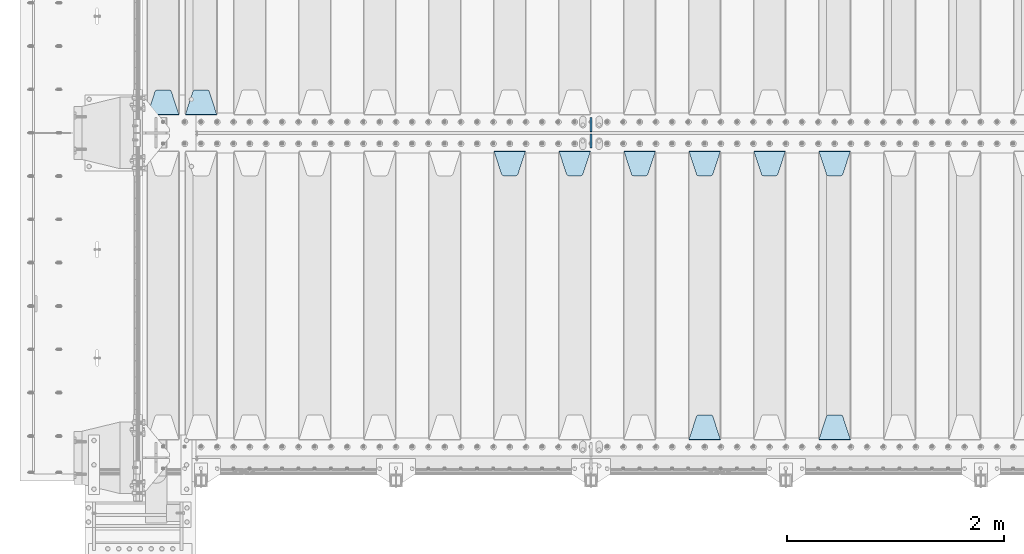
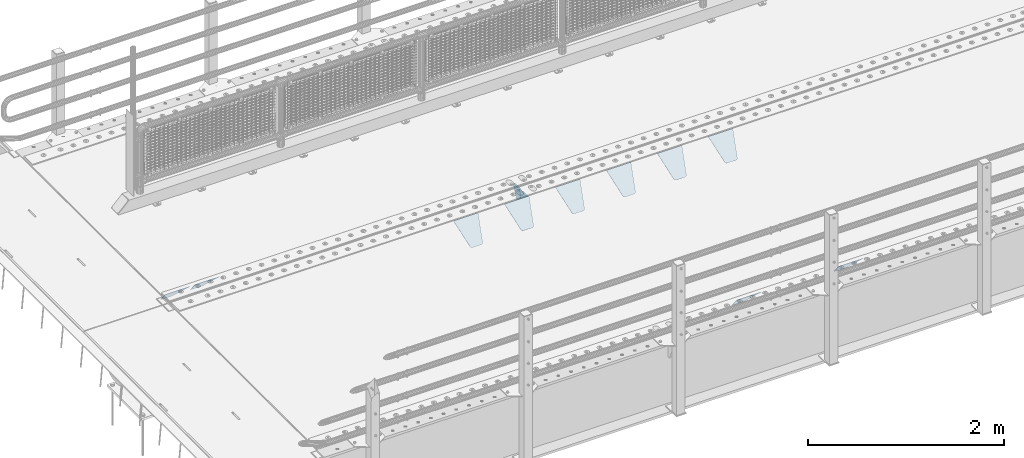
# One storey, part 157 of 193: 12 plates.
"""IFC2X3 building model written with IfcOpenShell, lengths in millimetres."""

from ifc_helpers import new_model, si_unit, frame, origin_with_axes, place, context, subcontext, project, spatial, faceted_brep, material, type_object, element, save


model = new_model("IFC2X3")

# Units and contexts
model_context = context("Model", 3, precision=1e-05, world=origin_with_axes())
body_context = subcontext(model_context, "Body", "Model", "MODEL_VIEW")
ifc_project = project(units=[si_unit("LENGTHUNIT", "METRE", prefix="MILLI"), si_unit("AREAUNIT", "SQUARE_METRE"), si_unit("VOLUMEUNIT", "CUBIC_METRE"), si_unit("MASSUNIT", "GRAM", prefix="KILO"), si_unit("TIMEUNIT", "SECOND"), si_unit("PLANEANGLEUNIT", "RADIAN"), si_unit("SOLIDANGLEUNIT", "STERADIAN"), si_unit("THERMODYNAMICTEMPERATUREUNIT", "DEGREE_CELSIUS"), si_unit("LUMINOUSINTENSITYUNIT", "LUMEN")], contexts=[model_context])

# Site, building, storey
site_placement = place(None, origin_with_axes())
site = spatial("IfcSite", under=ifc_project, at=site_placement, CompositionType="ELEMENT")
building_placement = place(site_placement, origin_with_axes())
building = spatial("IfcBuilding", under=site, at=building_placement, Name="Standard", CompositionType="ELEMENT")
storey_placement = place(building_placement, origin_with_axes())
storey = spatial("IfcBuildingStorey", under=building, at=storey_placement, Name="Undefined", CompositionType="ELEMENT", Elevation=0.0)

# Plates
ifc_material = material(Name="STEEL/S355N")
plate_type_1 = type_object("IfcPlateType", PredefinedType="NOTDEFINED")
plate_1_placement = place(storey_placement, frame((-41755.0, 27168.232233047, -1.76776695296758), z_axis=(0.0, 0.707106781186547, -0.707106781186548), x_axis=(-1.0, 0.0, 0.0)))
element("IfcPlate", 1, at=plate_1_placement, inside=storey, type_object=plate_type_1, material=ifc_material, context=body_context, shape_type="Brep", body=[
    faceted_brep([(0.0, -2.5, 0.0), (69.345504679477, -2.50000000000364, 300.171731424831), (69.345504679477, 2.49999999999636, 300.171731424831), (0.0, 2.5, 0.0), (70.9274061199576, -2.50000000000364, 304.897442415397), (70.9274061199576, 2.49999999999636, 304.897442415397), (73.3818627772307, -2.50000000000364, 309.234538108529), (73.3818627772307, 2.49999999999636, 309.234538108529), (76.6187032999551, -2.50000000000728, 313.023683126103), (76.6187032999551, 2.49999999999636, 313.023683126103), (80.5190132704993, -2.50000000000364, 316.125672595372), (80.5190132704993, 2.49999999999636, 316.125672595368), (84.9395038596849, -2.50000000000364, 318.426546230472), (84.9395038596849, 2.49999999999636, 318.426546230476), (89.7177759439219, -2.50000000000364, 319.841774983273), (89.7177759439219, 2.49999999999636, 319.841774983277), (94.678286292652, -2.50000000000364, 320.319366455074), (94.678286292652, 2.49999999999636, 320.319366455074), (195.321713707348, -2.50000000000364, 320.319366455074), (195.321713707348, 2.49999999999636, 320.319366455074), (200.282224056078, -2.50000000000364, 319.841774983273), (200.282224056078, 2.49999999999636, 319.841774983277), (205.060496140315, -2.50000000000364, 318.426546230472), (205.060496140315, 2.49999999999636, 318.426546230472), (209.480986729501, -2.50000000000364, 316.125672595372), (209.480986729501, 2.49999999999636, 316.125672595368), (213.381296700045, -2.50000000000728, 313.023683126103), (213.381296700045, 2.49999999999272, 313.023683126103), (216.618137222769, -2.50000000000364, 309.234538108525), (216.618137222769, 2.49999999999636, 309.234538108522), (219.072593880042, -2.50000000000364, 304.897442415397), (219.072593880042, 2.49999999999636, 304.897442415397), (220.654495320523, -2.50000000000364, 300.171731424831), (220.654495320523, 2.49999999999636, 300.171731424831), (290.0, -2.50000000000364, 0.0), (290.0, 2.49999999999636, 0.0)], [[[0, 1, 2, 3]], [[1, 4, 5, 2]], [[4, 6, 7, 5]], [[6, 8, 9, 7]], [[8, 10, 11, 9]], [[10, 12, 13, 11]], [[12, 14, 15, 13]], [[14, 16, 17, 15]], [[16, 18, 19, 17]], [[18, 20, 21, 19]], [[20, 22, 23, 21]], [[22, 24, 25, 23]], [[24, 26, 27, 25]], [[26, 28, 29, 27]], [[28, 30, 31, 29]], [[30, 32, 33, 31]], [[32, 34, 35, 33]], [[34, 0, 3, 35]], [[5, 7, 9, 11, 13, 15, 17, 19, 21, 23, 25, 27, 29, 31, 33, 35, 3, 2]], [[34, 32, 30, 28, 26, 24, 22, 20, 18, 16, 14, 12, 10, 8, 6, 4, 1, 0]]]),
])
plate_2_placement = place(storey_placement, frame((-36195.0, 26831.767766956, -1.76776695296758), z_axis=(0.0, -0.707106781186547, -0.707106781186548), x_axis=(1.0, 0.0, 0.0)))
element("IfcPlate", 2, at=plate_2_placement, inside=storey, type_object=plate_type_1, material=ifc_material, context=body_context, shape_type="Brep", body=[
    faceted_brep([(0.0, -2.5, 0.0), (69.345504679477, -2.50000000000364, 300.171731424831), (69.345504679477, 2.49999999999636, 300.171731424831), (0.0, 2.5, 0.0), (70.9274061199576, -2.50000000000364, 304.897442415397), (70.9274061199576, 2.49999999999636, 304.897442415397), (73.3818627772307, -2.50000000000364, 309.234538108529), (73.3818627772307, 2.49999999999636, 309.234538108529), (76.6187032999551, -2.50000000000728, 313.023683126103), (76.6187032999551, 2.49999999999636, 313.023683126103), (80.5190132704993, -2.50000000000364, 316.125672595372), (80.5190132704993, 2.49999999999636, 316.125672595368), (84.9395038596849, -2.50000000000364, 318.426546230472), (84.9395038596849, 2.49999999999636, 318.426546230476), (89.7177759439219, -2.50000000000364, 319.841774983273), (89.7177759439219, 2.49999999999636, 319.841774983277), (94.678286292652, -2.50000000000364, 320.319366455074), (94.678286292652, 2.49999999999636, 320.319366455074), (195.321713707348, -2.50000000000364, 320.319366455074), (195.321713707348, 2.49999999999636, 320.319366455074), (200.282224056078, -2.50000000000364, 319.841774983273), (200.282224056078, 2.49999999999636, 319.841774983277), (205.060496140315, -2.50000000000364, 318.426546230472), (205.060496140315, 2.49999999999636, 318.426546230472), (209.480986729501, -2.50000000000364, 316.125672595372), (209.480986729501, 2.49999999999636, 316.125672595368), (213.381296700045, -2.50000000000728, 313.023683126103), (213.381296700045, 2.49999999999272, 313.023683126103), (216.618137222769, -2.50000000000364, 309.234538108525), (216.618137222769, 2.49999999999636, 309.234538108522), (219.072593880042, -2.50000000000364, 304.897442415397), (219.072593880042, 2.49999999999636, 304.897442415397), (220.654495320523, -2.50000000000364, 300.171731424831), (220.654495320523, 2.49999999999636, 300.171731424831), (290.0, -2.50000000000364, 0.0), (290.0, 2.49999999999636, 0.0)], [[[0, 1, 2, 3]], [[1, 4, 5, 2]], [[4, 6, 7, 5]], [[6, 8, 9, 7]], [[8, 10, 11, 9]], [[10, 12, 13, 11]], [[12, 14, 15, 13]], [[14, 16, 17, 15]], [[16, 18, 19, 17]], [[18, 20, 21, 19]], [[20, 22, 23, 21]], [[22, 24, 25, 23]], [[24, 26, 27, 25]], [[26, 28, 29, 27]], [[28, 30, 31, 29]], [[30, 32, 33, 31]], [[32, 34, 35, 33]], [[34, 0, 3, 35]], [[5, 7, 9, 11, 13, 15, 17, 19, 21, 23, 25, 27, 29, 31, 33, 35, 3, 2]], [[34, 32, 30, 28, 26, 24, 22, 20, 18, 16, 14, 12, 10, 8, 6, 4, 1, 0]]]),
])
plate_3_placement = place(storey_placement, frame((-35905.0, 24168.232233047, -1.76776695296758), z_axis=(0.0, 0.707106781186547, -0.707106781186548), x_axis=(-1.0, 0.0, 0.0)))
element("IfcPlate", 3, at=plate_3_placement, inside=storey, type_object=plate_type_1, material=ifc_material, context=body_context, shape_type="Brep", body=[
    faceted_brep([(0.0, -2.5, 0.0), (69.345504679477, -2.50000000000364, 300.171731424831), (69.345504679477, 2.49999999999636, 300.171731424831), (0.0, 2.5, 0.0), (70.9274061199576, -2.50000000000364, 304.897442415397), (70.9274061199576, 2.49999999999636, 304.897442415397), (73.3818627772307, -2.50000000000364, 309.234538108529), (73.3818627772307, 2.49999999999636, 309.234538108529), (76.6187032999551, -2.50000000000728, 313.023683126103), (76.6187032999551, 2.49999999999636, 313.023683126103), (80.5190132704993, -2.50000000000364, 316.125672595372), (80.5190132704993, 2.49999999999636, 316.125672595368), (84.9395038596849, -2.50000000000364, 318.426546230472), (84.9395038596849, 2.49999999999636, 318.426546230476), (89.7177759439219, -2.50000000000364, 319.841774983273), (89.7177759439219, 2.49999999999636, 319.841774983277), (94.678286292652, -2.50000000000364, 320.319366455074), (94.678286292652, 2.49999999999636, 320.319366455074), (195.321713707348, -2.50000000000364, 320.319366455074), (195.321713707348, 2.49999999999636, 320.319366455074), (200.282224056078, -2.50000000000364, 319.841774983273), (200.282224056078, 2.49999999999636, 319.841774983277), (205.060496140315, -2.50000000000364, 318.426546230472), (205.060496140315, 2.49999999999636, 318.426546230472), (209.480986729501, -2.50000000000364, 316.125672595372), (209.480986729501, 2.49999999999636, 316.125672595368), (213.381296700045, -2.50000000000728, 313.023683126103), (213.381296700045, 2.49999999999272, 313.023683126103), (216.618137222769, -2.50000000000364, 309.234538108525), (216.618137222769, 2.49999999999636, 309.234538108522), (219.072593880042, -2.50000000000364, 304.897442415397), (219.072593880042, 2.49999999999636, 304.897442415397), (220.654495320523, -2.50000000000364, 300.171731424831), (220.654495320523, 2.49999999999636, 300.171731424831), (290.0, -2.50000000000364, 0.0), (290.0, 2.49999999999636, 0.0)], [[[0, 1, 2, 3]], [[1, 4, 5, 2]], [[4, 6, 7, 5]], [[6, 8, 9, 7]], [[8, 10, 11, 9]], [[10, 12, 13, 11]], [[12, 14, 15, 13]], [[14, 16, 17, 15]], [[16, 18, 19, 17]], [[18, 20, 21, 19]], [[20, 22, 23, 21]], [[22, 24, 25, 23]], [[24, 26, 27, 25]], [[26, 28, 29, 27]], [[28, 30, 31, 29]], [[30, 32, 33, 31]], [[32, 34, 35, 33]], [[34, 0, 3, 35]], [[5, 7, 9, 11, 13, 15, 17, 19, 21, 23, 25, 27, 29, 31, 33, 35, 3, 2]], [[34, 32, 30, 28, 26, 24, 22, 20, 18, 16, 14, 12, 10, 8, 6, 4, 1, 0]]]),
])
plate_4_placement = place(storey_placement, frame((-36795.0, 26831.767766956, -1.76776695296758), z_axis=(0.0, -0.707106781186547, -0.707106781186548), x_axis=(1.0, 0.0, 0.0)))
element("IfcPlate", 4, at=plate_4_placement, inside=storey, type_object=plate_type_1, material=ifc_material, context=body_context, shape_type="Brep", body=[
    faceted_brep([(0.0, -2.5, 0.0), (69.345504679477, -2.50000000000364, 300.171731424831), (69.345504679477, 2.49999999999636, 300.171731424831), (0.0, 2.5, 0.0), (70.9274061199576, -2.50000000000364, 304.897442415397), (70.9274061199576, 2.49999999999636, 304.897442415397), (73.3818627772307, -2.50000000000364, 309.234538108529), (73.3818627772307, 2.49999999999636, 309.234538108529), (76.6187032999551, -2.50000000000728, 313.023683126103), (76.6187032999551, 2.49999999999636, 313.023683126103), (80.5190132704993, -2.50000000000364, 316.125672595372), (80.5190132704993, 2.49999999999636, 316.125672595368), (84.9395038596849, -2.50000000000364, 318.426546230472), (84.9395038596849, 2.49999999999636, 318.426546230476), (89.7177759439219, -2.50000000000364, 319.841774983273), (89.7177759439219, 2.49999999999636, 319.841774983277), (94.678286292652, -2.50000000000364, 320.319366455074), (94.678286292652, 2.49999999999636, 320.319366455074), (195.321713707348, -2.50000000000364, 320.319366455074), (195.321713707348, 2.49999999999636, 320.319366455074), (200.282224056078, -2.50000000000364, 319.841774983273), (200.282224056078, 2.49999999999636, 319.841774983277), (205.060496140315, -2.50000000000364, 318.426546230472), (205.060496140315, 2.49999999999636, 318.426546230472), (209.480986729501, -2.50000000000364, 316.125672595372), (209.480986729501, 2.49999999999636, 316.125672595368), (213.381296700045, -2.50000000000728, 313.023683126103), (213.381296700045, 2.49999999999272, 313.023683126103), (216.618137222769, -2.50000000000364, 309.234538108525), (216.618137222769, 2.49999999999636, 309.234538108522), (219.072593880042, -2.50000000000364, 304.897442415397), (219.072593880042, 2.49999999999636, 304.897442415397), (220.654495320523, -2.50000000000364, 300.171731424831), (220.654495320523, 2.49999999999636, 300.171731424831), (290.0, -2.50000000000364, 0.0), (290.0, 2.49999999999636, 0.0)], [[[0, 1, 2, 3]], [[1, 4, 5, 2]], [[4, 6, 7, 5]], [[6, 8, 9, 7]], [[8, 10, 11, 9]], [[10, 12, 13, 11]], [[12, 14, 15, 13]], [[14, 16, 17, 15]], [[16, 18, 19, 17]], [[18, 20, 21, 19]], [[20, 22, 23, 21]], [[22, 24, 25, 23]], [[24, 26, 27, 25]], [[26, 28, 29, 27]], [[28, 30, 31, 29]], [[30, 32, 33, 31]], [[32, 34, 35, 33]], [[34, 0, 3, 35]], [[5, 7, 9, 11, 13, 15, 17, 19, 21, 23, 25, 27, 29, 31, 33, 35, 3, 2]], [[34, 32, 30, 28, 26, 24, 22, 20, 18, 16, 14, 12, 10, 8, 6, 4, 1, 0]]]),
])
plate_5_placement = place(storey_placement, frame((-37395.0, 26831.767766956, -1.76776695296758), z_axis=(0.0, -0.707106781186547, -0.707106781186548), x_axis=(1.0, 0.0, 0.0)))
element("IfcPlate", 5, at=plate_5_placement, inside=storey, type_object=plate_type_1, material=ifc_material, context=body_context, shape_type="Brep", body=[
    faceted_brep([(0.0, -2.5, 0.0), (69.345504679477, -2.50000000000364, 300.171731424831), (69.345504679477, 2.49999999999636, 300.171731424831), (0.0, 2.5, 0.0), (70.9274061199576, -2.50000000000364, 304.897442415397), (70.9274061199576, 2.49999999999636, 304.897442415397), (73.3818627772307, -2.50000000000364, 309.234538108529), (73.3818627772307, 2.49999999999636, 309.234538108529), (76.6187032999551, -2.50000000000728, 313.023683126103), (76.6187032999551, 2.49999999999636, 313.023683126103), (80.5190132704993, -2.50000000000364, 316.125672595372), (80.5190132704993, 2.49999999999636, 316.125672595368), (84.9395038596849, -2.50000000000364, 318.426546230472), (84.9395038596849, 2.49999999999636, 318.426546230476), (89.7177759439219, -2.50000000000364, 319.841774983273), (89.7177759439219, 2.49999999999636, 319.841774983277), (94.678286292652, -2.50000000000364, 320.319366455074), (94.678286292652, 2.49999999999636, 320.319366455074), (195.321713707348, -2.50000000000364, 320.319366455074), (195.321713707348, 2.49999999999636, 320.319366455074), (200.282224056078, -2.50000000000364, 319.841774983273), (200.282224056078, 2.49999999999636, 319.841774983277), (205.060496140315, -2.50000000000364, 318.426546230472), (205.060496140315, 2.49999999999636, 318.426546230472), (209.480986729501, -2.50000000000364, 316.125672595372), (209.480986729501, 2.49999999999636, 316.125672595368), (213.381296700045, -2.50000000000728, 313.023683126103), (213.381296700045, 2.49999999999272, 313.023683126103), (216.618137222769, -2.50000000000364, 309.234538108525), (216.618137222769, 2.49999999999636, 309.234538108522), (219.072593880042, -2.50000000000364, 304.897442415397), (219.072593880042, 2.49999999999636, 304.897442415397), (220.654495320523, -2.50000000000364, 300.171731424831), (220.654495320523, 2.49999999999636, 300.171731424831), (290.0, -2.50000000000364, 0.0), (290.0, 2.49999999999636, 0.0)], [[[0, 1, 2, 3]], [[1, 4, 5, 2]], [[4, 6, 7, 5]], [[6, 8, 9, 7]], [[8, 10, 11, 9]], [[10, 12, 13, 11]], [[12, 14, 15, 13]], [[14, 16, 17, 15]], [[16, 18, 19, 17]], [[18, 20, 21, 19]], [[20, 22, 23, 21]], [[22, 24, 25, 23]], [[24, 26, 27, 25]], [[26, 28, 29, 27]], [[28, 30, 31, 29]], [[30, 32, 33, 31]], [[32, 34, 35, 33]], [[34, 0, 3, 35]], [[5, 7, 9, 11, 13, 15, 17, 19, 21, 23, 25, 27, 29, 31, 33, 35, 3, 2]], [[34, 32, 30, 28, 26, 24, 22, 20, 18, 16, 14, 12, 10, 8, 6, 4, 1, 0]]]),
])
plate_6_placement = place(storey_placement, frame((-37105.0, 24168.232233047, -1.76776695296758), z_axis=(0.0, 0.707106781186547, -0.707106781186548), x_axis=(-1.0, 0.0, 0.0)))
element("IfcPlate", 6, at=plate_6_placement, inside=storey, type_object=plate_type_1, material=ifc_material, context=body_context, shape_type="Brep", body=[
    faceted_brep([(0.0, -2.5, 0.0), (69.345504679477, -2.50000000000364, 300.171731424831), (69.345504679477, 2.49999999999636, 300.171731424831), (0.0, 2.5, 0.0), (70.9274061199576, -2.50000000000364, 304.897442415397), (70.9274061199576, 2.49999999999636, 304.897442415397), (73.3818627772307, -2.50000000000364, 309.234538108529), (73.3818627772307, 2.49999999999636, 309.234538108529), (76.6187032999551, -2.50000000000728, 313.023683126103), (76.6187032999551, 2.49999999999636, 313.023683126103), (80.5190132704993, -2.50000000000364, 316.125672595372), (80.5190132704993, 2.49999999999636, 316.125672595368), (84.9395038596849, -2.50000000000364, 318.426546230472), (84.9395038596849, 2.49999999999636, 318.426546230476), (89.7177759439219, -2.50000000000364, 319.841774983273), (89.7177759439219, 2.49999999999636, 319.841774983277), (94.678286292652, -2.50000000000364, 320.319366455074), (94.678286292652, 2.49999999999636, 320.319366455074), (195.321713707348, -2.50000000000364, 320.319366455074), (195.321713707348, 2.49999999999636, 320.319366455074), (200.282224056078, -2.50000000000364, 319.841774983273), (200.282224056078, 2.49999999999636, 319.841774983277), (205.060496140315, -2.50000000000364, 318.426546230472), (205.060496140315, 2.49999999999636, 318.426546230472), (209.480986729501, -2.50000000000364, 316.125672595372), (209.480986729501, 2.49999999999636, 316.125672595368), (213.381296700045, -2.50000000000728, 313.023683126103), (213.381296700045, 2.49999999999272, 313.023683126103), (216.618137222769, -2.50000000000364, 309.234538108525), (216.618137222769, 2.49999999999636, 309.234538108522), (219.072593880042, -2.50000000000364, 304.897442415397), (219.072593880042, 2.49999999999636, 304.897442415397), (220.654495320523, -2.50000000000364, 300.171731424831), (220.654495320523, 2.49999999999636, 300.171731424831), (290.0, -2.50000000000364, 0.0), (290.0, 2.49999999999636, 0.0)], [[[0, 1, 2, 3]], [[1, 4, 5, 2]], [[4, 6, 7, 5]], [[6, 8, 9, 7]], [[8, 10, 11, 9]], [[10, 12, 13, 11]], [[12, 14, 15, 13]], [[14, 16, 17, 15]], [[16, 18, 19, 17]], [[18, 20, 21, 19]], [[20, 22, 23, 21]], [[22, 24, 25, 23]], [[24, 26, 27, 25]], [[26, 28, 29, 27]], [[28, 30, 31, 29]], [[30, 32, 33, 31]], [[32, 34, 35, 33]], [[34, 0, 3, 35]], [[5, 7, 9, 11, 13, 15, 17, 19, 21, 23, 25, 27, 29, 31, 33, 35, 3, 2]], [[34, 32, 30, 28, 26, 24, 22, 20, 18, 16, 14, 12, 10, 8, 6, 4, 1, 0]]]),
])
plate_7_placement = place(storey_placement, frame((-37995.0, 26831.767766956, -1.76776695296758), z_axis=(0.0, -0.707106781186547, -0.707106781186548), x_axis=(1.0, 0.0, 0.0)))
element("IfcPlate", 7, at=plate_7_placement, inside=storey, type_object=plate_type_1, material=ifc_material, context=body_context, shape_type="Brep", body=[
    faceted_brep([(0.0, -2.5, 0.0), (69.345504679477, -2.50000000000364, 300.171731424831), (69.345504679477, 2.49999999999636, 300.171731424831), (0.0, 2.5, 0.0), (70.9274061199576, -2.50000000000364, 304.897442415397), (70.9274061199576, 2.49999999999636, 304.897442415397), (73.3818627772307, -2.50000000000364, 309.234538108529), (73.3818627772307, 2.49999999999636, 309.234538108529), (76.6187032999551, -2.50000000000728, 313.023683126103), (76.6187032999551, 2.49999999999636, 313.023683126103), (80.5190132704993, -2.50000000000364, 316.125672595372), (80.5190132704993, 2.49999999999636, 316.125672595368), (84.9395038596849, -2.50000000000364, 318.426546230472), (84.9395038596849, 2.49999999999636, 318.426546230476), (89.7177759439219, -2.50000000000364, 319.841774983273), (89.7177759439219, 2.49999999999636, 319.841774983277), (94.678286292652, -2.50000000000364, 320.319366455074), (94.678286292652, 2.49999999999636, 320.319366455074), (195.321713707348, -2.50000000000364, 320.319366455074), (195.321713707348, 2.49999999999636, 320.319366455074), (200.282224056078, -2.50000000000364, 319.841774983273), (200.282224056078, 2.49999999999636, 319.841774983277), (205.060496140315, -2.50000000000364, 318.426546230472), (205.060496140315, 2.49999999999636, 318.426546230472), (209.480986729501, -2.50000000000364, 316.125672595372), (209.480986729501, 2.49999999999636, 316.125672595368), (213.381296700045, -2.50000000000728, 313.023683126103), (213.381296700045, 2.49999999999272, 313.023683126103), (216.618137222769, -2.50000000000364, 309.234538108525), (216.618137222769, 2.49999999999636, 309.234538108522), (219.072593880042, -2.50000000000364, 304.897442415397), (219.072593880042, 2.49999999999636, 304.897442415397), (220.654495320523, -2.50000000000364, 300.171731424831), (220.654495320523, 2.49999999999636, 300.171731424831), (290.0, -2.50000000000364, 0.0), (290.0, 2.49999999999636, 0.0)], [[[0, 1, 2, 3]], [[1, 4, 5, 2]], [[4, 6, 7, 5]], [[6, 8, 9, 7]], [[8, 10, 11, 9]], [[10, 12, 13, 11]], [[12, 14, 15, 13]], [[14, 16, 17, 15]], [[16, 18, 19, 17]], [[18, 20, 21, 19]], [[20, 22, 23, 21]], [[22, 24, 25, 23]], [[24, 26, 27, 25]], [[26, 28, 29, 27]], [[28, 30, 31, 29]], [[30, 32, 33, 31]], [[32, 34, 35, 33]], [[34, 0, 3, 35]], [[5, 7, 9, 11, 13, 15, 17, 19, 21, 23, 25, 27, 29, 31, 33, 35, 3, 2]], [[34, 32, 30, 28, 26, 24, 22, 20, 18, 16, 14, 12, 10, 8, 6, 4, 1, 0]]]),
])
plate_8_placement = place(storey_placement, frame((-38595.0, 26831.767766956, -1.76776695296758), z_axis=(0.0, -0.707106781186547, -0.707106781186548), x_axis=(1.0, 0.0, 0.0)))
element("IfcPlate", 8, at=plate_8_placement, inside=storey, type_object=plate_type_1, material=ifc_material, context=body_context, shape_type="Brep", body=[
    faceted_brep([(0.0, -2.5, 0.0), (69.345504679477, -2.50000000000364, 300.171731424831), (69.345504679477, 2.49999999999636, 300.171731424831), (0.0, 2.5, 0.0), (70.9274061199576, -2.50000000000364, 304.897442415397), (70.9274061199576, 2.49999999999636, 304.897442415397), (73.3818627772307, -2.50000000000364, 309.234538108529), (73.3818627772307, 2.49999999999636, 309.234538108529), (76.6187032999551, -2.50000000000728, 313.023683126103), (76.6187032999551, 2.49999999999636, 313.023683126103), (80.5190132704993, -2.50000000000364, 316.125672595372), (80.5190132704993, 2.49999999999636, 316.125672595368), (84.9395038596849, -2.50000000000364, 318.426546230472), (84.9395038596849, 2.49999999999636, 318.426546230476), (89.7177759439219, -2.50000000000364, 319.841774983273), (89.7177759439219, 2.49999999999636, 319.841774983277), (94.678286292652, -2.50000000000364, 320.319366455074), (94.678286292652, 2.49999999999636, 320.319366455074), (195.321713707348, -2.50000000000364, 320.319366455074), (195.321713707348, 2.49999999999636, 320.319366455074), (200.282224056078, -2.50000000000364, 319.841774983273), (200.282224056078, 2.49999999999636, 319.841774983277), (205.060496140315, -2.50000000000364, 318.426546230472), (205.060496140315, 2.49999999999636, 318.426546230472), (209.480986729501, -2.50000000000364, 316.125672595372), (209.480986729501, 2.49999999999636, 316.125672595368), (213.381296700045, -2.50000000000728, 313.023683126103), (213.381296700045, 2.49999999999272, 313.023683126103), (216.618137222769, -2.50000000000364, 309.234538108525), (216.618137222769, 2.49999999999636, 309.234538108522), (219.072593880042, -2.50000000000364, 304.897442415397), (219.072593880042, 2.49999999999636, 304.897442415397), (220.654495320523, -2.50000000000364, 300.171731424831), (220.654495320523, 2.49999999999636, 300.171731424831), (290.0, -2.50000000000364, 0.0), (290.0, 2.49999999999636, 0.0)], [[[0, 1, 2, 3]], [[1, 4, 5, 2]], [[4, 6, 7, 5]], [[6, 8, 9, 7]], [[8, 10, 11, 9]], [[10, 12, 13, 11]], [[12, 14, 15, 13]], [[14, 16, 17, 15]], [[16, 18, 19, 17]], [[18, 20, 21, 19]], [[20, 22, 23, 21]], [[22, 24, 25, 23]], [[24, 26, 27, 25]], [[26, 28, 29, 27]], [[28, 30, 31, 29]], [[30, 32, 33, 31]], [[32, 34, 35, 33]], [[34, 0, 3, 35]], [[5, 7, 9, 11, 13, 15, 17, 19, 21, 23, 25, 27, 29, 31, 33, 35, 3, 2]], [[34, 32, 30, 28, 26, 24, 22, 20, 18, 16, 14, 12, 10, 8, 6, 4, 1, 0]]]),
])
plate_9_placement = place(storey_placement, frame((-39195.0, 26831.767766956, -1.76776695296758), z_axis=(0.0, -0.707106781186547, -0.707106781186548), x_axis=(1.0, 0.0, 0.0)))
element("IfcPlate", 9, at=plate_9_placement, inside=storey, type_object=plate_type_1, material=ifc_material, context=body_context, shape_type="Brep", body=[
    faceted_brep([(0.0, -2.5, 0.0), (69.345504679477, -2.50000000000364, 300.171731424831), (69.345504679477, 2.49999999999636, 300.171731424831), (0.0, 2.5, 0.0), (70.9274061199576, -2.50000000000364, 304.897442415397), (70.9274061199576, 2.49999999999636, 304.897442415397), (73.3818627772307, -2.50000000000364, 309.234538108529), (73.3818627772307, 2.49999999999636, 309.234538108529), (76.6187032999551, -2.50000000000728, 313.023683126103), (76.6187032999551, 2.49999999999636, 313.023683126103), (80.5190132704993, -2.50000000000364, 316.125672595372), (80.5190132704993, 2.49999999999636, 316.125672595368), (84.9395038596849, -2.50000000000364, 318.426546230472), (84.9395038596849, 2.49999999999636, 318.426546230476), (89.7177759439219, -2.50000000000364, 319.841774983273), (89.7177759439219, 2.49999999999636, 319.841774983277), (94.678286292652, -2.50000000000364, 320.319366455074), (94.678286292652, 2.49999999999636, 320.319366455074), (195.321713707348, -2.50000000000364, 320.319366455074), (195.321713707348, 2.49999999999636, 320.319366455074), (200.282224056078, -2.50000000000364, 319.841774983273), (200.282224056078, 2.49999999999636, 319.841774983277), (205.060496140315, -2.50000000000364, 318.426546230472), (205.060496140315, 2.49999999999636, 318.426546230472), (209.480986729501, -2.50000000000364, 316.125672595372), (209.480986729501, 2.49999999999636, 316.125672595368), (213.381296700045, -2.50000000000728, 313.023683126103), (213.381296700045, 2.49999999999272, 313.023683126103), (216.618137222769, -2.50000000000364, 309.234538108525), (216.618137222769, 2.49999999999636, 309.234538108522), (219.072593880042, -2.50000000000364, 304.897442415397), (219.072593880042, 2.49999999999636, 304.897442415397), (220.654495320523, -2.50000000000364, 300.171731424831), (220.654495320523, 2.49999999999636, 300.171731424831), (290.0, -2.50000000000364, 0.0), (290.0, 2.49999999999636, 0.0)], [[[0, 1, 2, 3]], [[1, 4, 5, 2]], [[4, 6, 7, 5]], [[6, 8, 9, 7]], [[8, 10, 11, 9]], [[10, 12, 13, 11]], [[12, 14, 15, 13]], [[14, 16, 17, 15]], [[16, 18, 19, 17]], [[18, 20, 21, 19]], [[20, 22, 23, 21]], [[22, 24, 25, 23]], [[24, 26, 27, 25]], [[26, 28, 29, 27]], [[28, 30, 31, 29]], [[30, 32, 33, 31]], [[32, 34, 35, 33]], [[34, 0, 3, 35]], [[5, 7, 9, 11, 13, 15, 17, 19, 21, 23, 25, 27, 29, 31, 33, 35, 3, 2]], [[34, 32, 30, 28, 26, 24, 22, 20, 18, 16, 14, 12, 10, 8, 6, 4, 1, 0]]]),
])
plate_10_placement = place(storey_placement, frame((-42105.0, 27168.232233047, -1.76776695296758), z_axis=(0.0, 0.707106781186547, -0.707106781186548), x_axis=(-1.0, 0.0, 0.0)))
element("IfcPlate", 10, at=plate_10_placement, inside=storey, type_object=plate_type_1, material=ifc_material, context=body_context, shape_type="Brep", body=[
    faceted_brep([(0.0, -2.5, 0.0), (69.345504679477, -2.50000000000364, 300.171731424831), (69.345504679477, 2.49999999999636, 300.171731424831), (0.0, 2.5, 0.0), (70.9274061199576, -2.50000000000364, 304.897442415397), (70.9274061199576, 2.49999999999636, 304.897442415397), (73.3818627772307, -2.50000000000364, 309.234538108529), (73.3818627772307, 2.49999999999636, 309.234538108529), (76.6187032999551, -2.50000000000728, 313.023683126103), (76.6187032999551, 2.49999999999636, 313.023683126103), (80.5190132704993, -2.50000000000364, 316.125672595372), (80.5190132704993, 2.49999999999636, 316.125672595368), (84.9395038596849, -2.50000000000364, 318.426546230472), (84.9395038596849, 2.49999999999636, 318.426546230476), (89.7177759439219, -2.50000000000364, 319.841774983273), (89.7177759439219, 2.49999999999636, 319.841774983277), (94.678286292652, -2.50000000000364, 320.319366455074), (94.678286292652, 2.49999999999636, 320.319366455074), (195.321713707348, -2.50000000000364, 320.319366455074), (195.321713707348, 2.49999999999636, 320.319366455074), (200.282224056078, -2.50000000000364, 319.841774983273), (200.282224056078, 2.49999999999636, 319.841774983277), (205.060496140315, -2.50000000000364, 318.426546230472), (205.060496140315, 2.49999999999636, 318.426546230472), (209.480986729501, -2.50000000000364, 316.125672595372), (209.480986729501, 2.49999999999636, 316.125672595368), (213.381296700045, -2.50000000000728, 313.023683126103), (213.381296700045, 2.49999999999272, 313.023683126103), (216.618137222769, -2.50000000000364, 309.234538108525), (216.618137222769, 2.49999999999636, 309.234538108522), (219.072593880042, -2.50000000000364, 304.897442415397), (219.072593880042, 2.49999999999636, 304.897442415397), (220.654495320523, -2.50000000000364, 300.171731424831), (220.654495320523, 2.49999999999636, 300.171731424831), (290.0, -2.50000000000364, 0.0), (290.0, 2.49999999999636, 0.0)], [[[0, 1, 2, 3]], [[1, 4, 5, 2]], [[4, 6, 7, 5]], [[6, 8, 9, 7]], [[8, 10, 11, 9]], [[10, 12, 13, 11]], [[12, 14, 15, 13]], [[14, 16, 17, 15]], [[16, 18, 19, 17]], [[18, 20, 21, 19]], [[20, 22, 23, 21]], [[22, 24, 25, 23]], [[24, 26, 27, 25]], [[26, 28, 29, 27]], [[28, 30, 31, 29]], [[30, 32, 33, 31]], [[32, 34, 35, 33]], [[34, 0, 3, 35]], [[5, 7, 9, 11, 13, 15, 17, 19, 21, 23, 25, 27, 29, 31, 33, 35, 3, 2]], [[34, 32, 30, 28, 26, 24, 22, 20, 18, 16, 14, 12, 10, 8, 6, 4, 1, 0]]]),
])
plate_type_2 = type_object("IfcPlateType", PredefinedType="NOTDEFINED")
for number, where, z_axis, x_axis in (
    (11, (-38300.0, 26860.0, -30.0), (0.0, 0.0, -1.0), (0.0, 1.0, 0.0)),
    (12, (-38300.0, 27140.0, -30.0), (0.0, 0.0, -1.0), (0.0, -1.0, 0.0)),
):
    element("IfcPlate", number, at=place(storey_placement, frame(where, z_axis=z_axis, x_axis=x_axis)), inside=storey, type_object=plate_type_2, material=ifc_material, context=body_context, shape_type="Brep", body=[
        faceted_brep([(0.0, -10.0, 0.0), (0.0, -10.0, 30.0), (0.0, 10.0, 30.0), (0.0, 10.0, 0.0), (102.0, -10.0, 250.0), (102.0, 10.0, 250.0), (132.0, -10.0, 250.0), (132.0, 10.0, 250.0), (132.0, -10.0, 30.0), (132.0, 10.0, 30.0), (131.544232590368, -10.0, 24.790554669992), (131.544232590368, 10.0, 24.790554669992), (130.190778623579, -10.0, 19.7393957002299), (130.190778623579, 10.0, 19.7393957002299), (127.980762113533, -10.0, 15.0), (127.980762113533, 10.0, 15.0), (124.98133329357, -10.0, 10.7163717094038), (124.98133329357, 10.0, 10.7163717094038), (121.283628290596, -10.0, 7.01866670643062), (121.283628290596, 10.0, 7.01866670643062), (117.0, -10.0, 4.01923788646684), (117.0, 10.0, 4.01923788646684), (112.260604299769, -10.0, 1.80922137642278), (112.260604299769, 10.0, 1.80922137642278), (107.209445330009, -10.0, 0.455767409633722), (107.209445330009, 10.0, 0.455767409633722), (102.0, -10.0, 0.0), (102.0, 10.0, 0.0)], [[[0, 1, 2, 3]], [[1, 4, 5, 2]], [[4, 6, 7, 5]], [[6, 8, 9, 7]], [[8, 10, 11, 9]], [[10, 12, 13, 11]], [[12, 14, 15, 13]], [[14, 16, 17, 15]], [[16, 18, 19, 17]], [[18, 20, 21, 19]], [[20, 22, 23, 21]], [[22, 24, 25, 23]], [[24, 26, 27, 25]], [[26, 0, 3, 27]], [[5, 7, 9, 11, 13, 15, 17, 19, 21, 23, 25, 27, 3, 2]], [[26, 24, 22, 20, 18, 16, 14, 12, 10, 8, 6, 4, 1, 0]]]),
    ])

save(model, "model.ifc")
